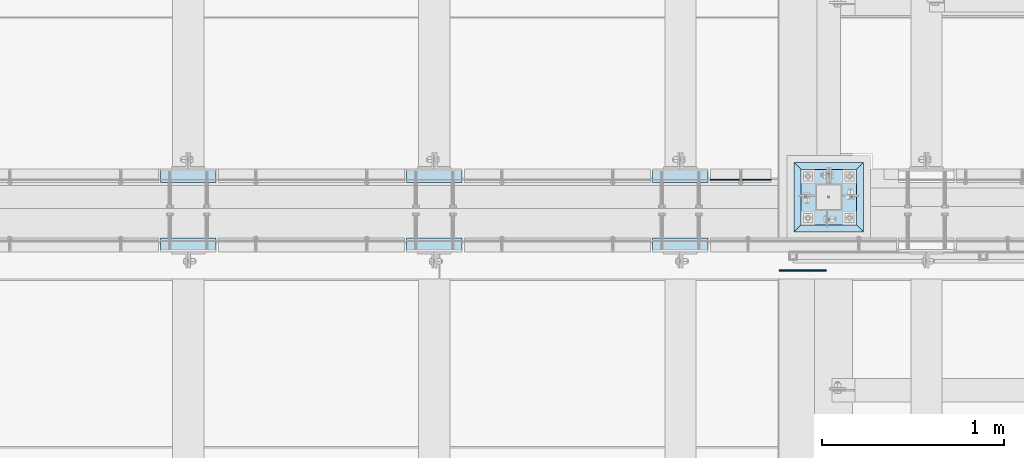
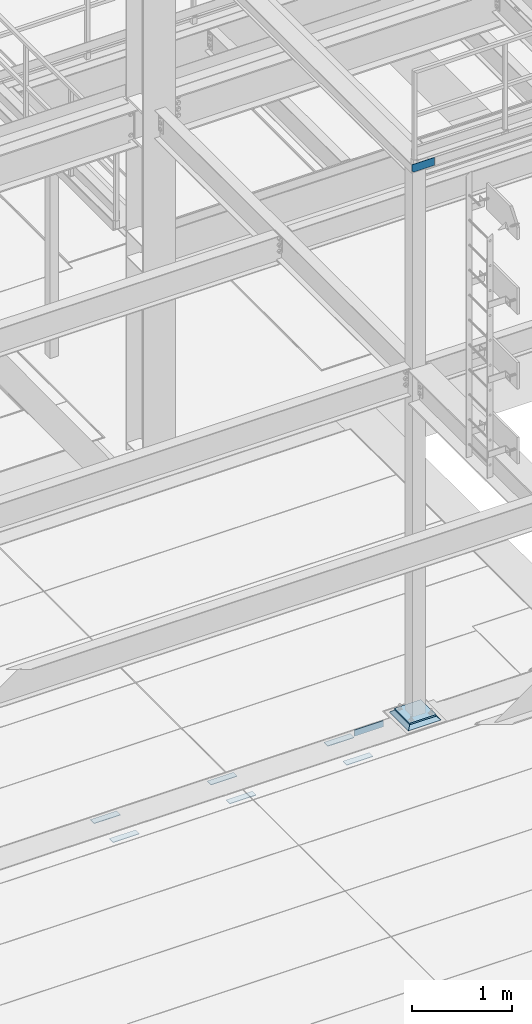
# One storey, part 3105 of 3843: 10 plates, 10 elements without a shape of their own.
"""IFC2X3 building model written with IfcOpenShell, lengths in millimetres."""

from ifc_helpers import new_model, si_unit, frame, origin_with_axes, place, context, subcontext, project, spatial, faceted_brep, material, type_object, element, aggregate, save


model = new_model("IFC2X3")

# Units and contexts
model_context = context("Model", 3, precision=1e-05, world=origin_with_axes())
body_context = subcontext(model_context, "Body", "Model", "MODEL_VIEW")
ifc_project = project(units=[si_unit("LENGTHUNIT", "METRE", prefix="MILLI"), si_unit("AREAUNIT", "SQUARE_METRE"), si_unit("VOLUMEUNIT", "CUBIC_METRE"), si_unit("MASSUNIT", "GRAM", prefix="KILO"), si_unit("TIMEUNIT", "SECOND"), si_unit("PLANEANGLEUNIT", "RADIAN"), si_unit("SOLIDANGLEUNIT", "STERADIAN"), si_unit("THERMODYNAMICTEMPERATUREUNIT", "DEGREE_CELSIUS"), si_unit("LUMINOUSINTENSITYUNIT", "LUMEN")], contexts=[model_context])

# Site, building, storey
site_placement = place(None, origin_with_axes())
site = spatial("IfcSite", under=ifc_project, at=site_placement, CompositionType="ELEMENT")
building_placement = place(site_placement, origin_with_axes())
building = spatial("IfcBuilding", under=site, at=building_placement, Name="Undefined", CompositionType="ELEMENT")
storey_placement = place(building_placement, origin_with_axes())
storey = spatial("IfcBuildingStorey", under=building, at=storey_placement, Name="Undefined", CompositionType="ELEMENT", Elevation=0.0)

# Assembly, plate
assembly_1_placement = place(storey_placement, origin_with_axes())
assembly_1 = element("IfcElementAssembly", 1, at=assembly_1_placement, inside=storey, Name="EMBED PLATE", AssemblyPlace="NOTDEFINED", PredefinedType="RIGID_FRAME")
ifc_material_1 = material(Name="STEEL/A36")
plate_type_1 = type_object("IfcPlateType", PredefinedType="NOTDEFINED")
plate_1_placement = place(assembly_1_placement, frame((45627.925, 20005.6749969482, 30400.625), z_axis=(-1.0, 0.0, 0.0), x_axis=(0.0, 1.0, 0.0)))
plate_1 = element("IfcPlate", 2, at=plate_1_placement, type_object=plate_type_1, material=ifc_material_1, Name="PLATE", context=body_context, shape_type="Brep", body=[
    faceted_brep([(0.0, -3.17499999999927, 0.0), (0.0, -3.17499999999927, 304.800000000003), (0.0, 3.17499999999927, 304.800000000003), (0.0, 3.17499999999927, 0.0), (76.1999999999971, -3.17499999999927, 304.799999999996), (76.1999999999971, 3.17499999999927, 304.799999999996), (76.1999999999971, -3.17499999999927, 0.0), (76.1999999999971, 3.17499999999927, 0.0)], [[[0, 1, 2, 3]], [[1, 4, 5, 2]], [[4, 6, 7, 5]], [[6, 0, 3, 7]], [[5, 7, 3, 2]], [[6, 4, 1, 0]]]),
])
aggregate(assembly_1, [plate_1])

assembly_2_placement = place(storey_placement, origin_with_axes())
assembly_2 = element("IfcElementAssembly", 3, at=assembly_2_placement, inside=storey, Name="EMBED PLATE", AssemblyPlace="NOTDEFINED", PredefinedType="RIGID_FRAME")
plate_2_placement = place(assembly_2_placement, frame((46980.475, 20005.6749969482, 30400.625), z_axis=(-1.0, 0.0, 0.0), x_axis=(0.0, 1.0, 0.0)))
plate_2 = element("IfcPlate", 4, at=plate_2_placement, type_object=plate_type_1, material=ifc_material_1, Name="PLATE", context=body_context, shape_type="Brep", body=[
    faceted_brep([(0.0, -3.17499999999927, 0.0), (0.0, -3.17499999999927, 304.800000000003), (0.0, 3.17499999999927, 304.800000000003), (0.0, 3.17499999999927, 0.0), (76.1999999999971, -3.17499999999927, 304.799999999996), (76.1999999999971, 3.17499999999927, 304.799999999996), (76.1999999999971, -3.17499999999927, 0.0), (76.1999999999971, 3.17499999999927, 0.0)], [[[0, 1, 2, 3]], [[1, 4, 5, 2]], [[4, 6, 7, 5]], [[6, 0, 3, 7]], [[5, 7, 3, 2]], [[6, 4, 1, 0]]]),
])
aggregate(assembly_2, [plate_2])

assembly_3_placement = place(storey_placement, origin_with_axes())
assembly_3 = element("IfcElementAssembly", 5, at=assembly_3_placement, inside=storey, Name="EMBED PLATE", AssemblyPlace="NOTDEFINED", PredefinedType="RIGID_FRAME")
plate_3_placement = place(assembly_3_placement, frame((48333.025, 20005.6749969482, 30400.625), z_axis=(-1.0, 0.0, 0.0), x_axis=(0.0, 1.0, 0.0)))
plate_3 = element("IfcPlate", 6, at=plate_3_placement, type_object=plate_type_1, material=ifc_material_1, Name="PLATE", context=body_context, shape_type="Brep", body=[
    faceted_brep([(0.0, -3.17499999999927, 0.0), (0.0, -3.17499999999927, 304.800000000003), (0.0, 3.17499999999927, 304.800000000003), (0.0, 3.17499999999927, 0.0), (76.1999999999971, -3.17499999999927, 304.799999999996), (76.1999999999971, 3.17499999999927, 304.799999999996), (76.1999999999971, -3.17499999999927, 0.0), (76.1999999999971, 3.17499999999927, 0.0)], [[[0, 1, 2, 3]], [[1, 4, 5, 2]], [[4, 6, 7, 5]], [[6, 0, 3, 7]], [[5, 7, 3, 2]], [[6, 4, 1, 0]]]),
])
aggregate(assembly_3, [plate_3])

assembly_4_placement = place(storey_placement, origin_with_axes())
assembly_4 = element("IfcElementAssembly", 7, at=assembly_4_placement, inside=storey, Name="EMBED PLATE", AssemblyPlace="NOTDEFINED", PredefinedType="RIGID_FRAME")
plate_4_placement = place(assembly_4_placement, frame((48028.225, 20462.8750030518, 30400.625), z_axis=(1.0, 0.0, 0.0), x_axis=(0.0, -1.0, 0.0)))
plate_4 = element("IfcPlate", 8, at=plate_4_placement, type_object=plate_type_1, material=ifc_material_1, Name="PLATE", context=body_context, shape_type="Brep", body=[
    faceted_brep([(0.0, -3.17499999999927, 0.0), (0.0, -3.17499999999927, 304.800000000003), (0.0, 3.17499999999927, 304.800000000003), (0.0, 3.17499999999927, 0.0), (76.1999999999971, -3.17499999999927, 304.799999999996), (76.1999999999971, 3.17499999999927, 304.799999999996), (76.1999999999971, -3.17499999999927, 0.0), (76.1999999999971, 3.17499999999927, 0.0)], [[[0, 1, 2, 3]], [[1, 4, 5, 2]], [[4, 6, 7, 5]], [[6, 0, 3, 7]], [[5, 7, 3, 2]], [[6, 4, 1, 0]]]),
])
aggregate(assembly_4, [plate_4])

assembly_5_placement = place(storey_placement, origin_with_axes())
assembly_5 = element("IfcElementAssembly", 9, at=assembly_5_placement, inside=storey, Name="EMBED PLATE", AssemblyPlace="NOTDEFINED", PredefinedType="RIGID_FRAME")
plate_5_placement = place(assembly_5_placement, frame((46675.675, 20462.8750030517, 30400.625), z_axis=(1.0, 0.0, 0.0), x_axis=(0.0, -1.0, 0.0)))
plate_5 = element("IfcPlate", 10, at=plate_5_placement, type_object=plate_type_1, material=ifc_material_1, Name="PLATE", context=body_context, shape_type="Brep", body=[
    faceted_brep([(0.0, -3.17499999999927, 0.0), (0.0, -3.17499999999927, 304.800000000003), (0.0, 3.17499999999927, 304.800000000003), (0.0, 3.17499999999927, 0.0), (76.1999999999971, -3.17499999999927, 304.799999999996), (76.1999999999971, 3.17499999999927, 304.799999999996), (76.1999999999971, -3.17499999999927, 0.0), (76.1999999999971, 3.17499999999927, 0.0)], [[[0, 1, 2, 3]], [[1, 4, 5, 2]], [[4, 6, 7, 5]], [[6, 0, 3, 7]], [[5, 7, 3, 2]], [[6, 4, 1, 0]]]),
])
aggregate(assembly_5, [plate_5])

assembly_6_placement = place(storey_placement, origin_with_axes())
assembly_6 = element("IfcElementAssembly", 11, at=assembly_6_placement, inside=storey, Name="EMBED PLATE", AssemblyPlace="NOTDEFINED", PredefinedType="RIGID_FRAME")
plate_6_placement = place(assembly_6_placement, frame((45323.125, 20462.8750030517, 30400.625), z_axis=(1.0, 0.0, 0.0), x_axis=(0.0, -1.0, 0.0)))
plate_6 = element("IfcPlate", 12, at=plate_6_placement, type_object=plate_type_1, material=ifc_material_1, Name="PLATE", context=body_context, shape_type="Brep", body=[
    faceted_brep([(0.0, -3.17499999999927, 0.0), (0.0, -3.17499999999927, 304.800000000003), (0.0, 3.17499999999927, 304.800000000003), (0.0, 3.17499999999927, 0.0), (76.1999999999971, -3.17499999999927, 304.799999999996), (76.1999999999971, 3.17499999999927, 304.799999999996), (76.1999999999971, -3.17499999999927, 0.0), (76.1999999999971, 3.17499999999927, 0.0)], [[[0, 1, 2, 3]], [[1, 4, 5, 2]], [[4, 6, 7, 5]], [[6, 0, 3, 7]], [[5, 7, 3, 2]], [[6, 4, 1, 0]]]),
])
aggregate(assembly_6, [plate_6])

assembly_7_placement = place(storey_placement, origin_with_axes())
assembly_7 = element("IfcElementAssembly", 13, at=assembly_7_placement, inside=storey, Name="ANGLE", AssemblyPlace="NOTDEFINED", PredefinedType="RIGID_FRAME")
plate_7_placement = place(assembly_7_placement, frame((48679.1, 20402.550002507, 30403.8000030518), z_axis=(-1.0, 0.0, 0.0), x_axis=(0.0, 0.0, 1.0)))
plate_7 = element("IfcPlate", 14, at=plate_7_placement, type_object=plate_type_1, material=ifc_material_1, Name="PLATE", context=body_context, shape_type="Brep", body=[
    faceted_brep([(0.0, -3.17499999999927, 0.0), (-8.73789031174965e-06, -3.17499999999927, 333.339925019733), (-8.73789031174965e-06, 3.17499999999927, 333.339925019733), (0.0, 3.17499999999927, 0.0), (76.1999934112064, -3.17499999999927, 333.339925019987), (76.1999934112064, 3.17499999999927, 333.339925019987), (76.1999999999971, -3.17499999999927, 0.0), (76.1999999999971, 3.17499999999927, 0.0)], [[[0, 1, 2, 3]], [[1, 4, 5, 2]], [[4, 6, 7, 5]], [[6, 0, 3, 7]], [[5, 7, 3, 2]], [[6, 4, 1, 0]]]),
])
aggregate(assembly_7, [plate_7])

assembly_8_placement = place(storey_placement, origin_with_axes())
assembly_8 = element("IfcElementAssembly", 15, at=assembly_8_placement, inside=storey, Name="BEAM", AssemblyPlace="NOTDEFINED", PredefinedType="RIGID_FRAME")
ifc_material_2 = material(Name="STEEL/A572-50")
plate_type_2 = type_object("IfcPlateType", PredefinedType="NOTDEFINED")
plate_8_placement = place(assembly_8_placement, frame((48723.55, 19904.075, 37471.35), z_axis=(0.0, 0.0, 1.0), x_axis=(1.0, 0.0, 0.0)))
plate_8 = element("IfcPlate", 16, at=plate_8_placement, type_object=plate_type_2, material=ifc_material_2, Name="PLATE", context=body_context, shape_type="Brep", body=[
    faceted_brep([(4.36557456851006e-11, -3.17499999998836, 19.0499992370969), (0.0, -3.17499999999927, 95.25), (-2.44140610448085e-05, 3.17500000000291, 95.2499999999927), (1.45519152283669e-11, 3.17499999998836, 19.0499992370824), (260.350006103516, -3.17499999999927, 95.25), (260.350006103516, 3.17499999999927, 95.25), (260.350006103516, -3.17499999999927, 0.0), (260.350006103516, 3.17499999999927, 0.0), (19.0499992370023, -3.17500000005384, 0.0), (19.0499992369587, 3.17499999992287, -1.45519152283669e-11)], [[[0, 1, 2, 3]], [[1, 4, 5, 2]], [[4, 6, 7, 5]], [[6, 8, 9, 7]], [[8, 0, 3, 9]], [[5, 7, 9, 3, 2]], [[8, 6, 4, 1, 0]]]),
])
aggregate(assembly_8, [plate_8])

assembly_9_placement = place(storey_placement, origin_with_axes())
assembly_9 = element("IfcElementAssembly", 17, at=assembly_9_placement, inside=storey, Name="GROUT", AssemblyPlace="NOTDEFINED", PredefinedType="REINFORCEMENT_UNIT")
ifc_material_3 = material(Name="CONCRETE/Concrete_Undefined")
plate_type_3 = type_object("IfcPlateType", PredefinedType="NOTDEFINED")
plate_9_placement = place(assembly_9_placement, frame((48806.1, 20116.8, 30499.05), z_axis=(0.0, 1.0, 0.0), x_axis=(1.0, 0.0, 0.0)))
plate_9 = element("IfcPlate", 18, at=plate_9_placement, type_object=plate_type_3, material=ifc_material_3, Name="GROUT", context=body_context, shape_type="Brep", body=[
    faceted_brep([(38.0999999997948, -19.0499999997846, 342.900000000212), (0.0, 19.0499999999993, 381.0), (0.0, 19.0500000000029, 0.0), (38.1000000006916, -19.0499999999811, 38.1000000006607), (342.90000000022, -19.0499999998137, 38.0999999997985), (381.0, 19.0499999999993, 0.0), (381.0, 19.0499999999993, 381.0), (342.90000000022, -19.0499999999811, 342.900000000212)], [[[0, 1, 2, 3]], [[4, 5, 6, 7]], [[4, 7, 0, 3]], [[5, 4, 3, 2]], [[6, 5, 2, 1]], [[7, 6, 1, 0]]]),
])
aggregate(assembly_9, [plate_9])

assembly_10_placement = place(storey_placement, origin_with_axes())
assembly_10 = element("IfcElementAssembly", 19, at=assembly_10_placement, inside=storey, Name="COLUMN", AssemblyPlace="NOTDEFINED", PredefinedType="RIGID_FRAME")
plate_type_4 = type_object("IfcPlateType", PredefinedType="NOTDEFINED")
plate_10_placement = place(assembly_10_placement, frame((48844.2, 20154.9, 30527.625), z_axis=(0.0, 1.0, 0.0), x_axis=(1.0, 0.0, 0.0)))
plate_10 = element("IfcPlate", 20, at=plate_10_placement, type_object=plate_type_4, material=ifc_material_2, Name="PLATE", context=body_context, shape_type="Brep", body=[
    faceted_brep([(0.0, -9.52500000000146, 0.0), (1.81898940354586e-12, -9.52500000000146, 304.800000000003), (1.81898940354586e-12, 9.52500000000146, 304.800000000003), (0.0, 9.52500000000146, 0.0), (304.799987792969, -9.52500000000146, 304.799987792969), (304.799987792969, 9.52500000000146, 304.799987792969), (304.799987792969, -9.52500000000146, 0.0), (304.799987792969, 9.52500000000146, 0.0)], [[[0, 1, 2, 3]], [[1, 4, 5, 2]], [[4, 6, 7, 5]], [[6, 0, 3, 7]], [[5, 7, 3, 2]], [[6, 4, 1, 0]]]),
])
aggregate(assembly_10, [plate_10])

save(model, "model.ifc")
